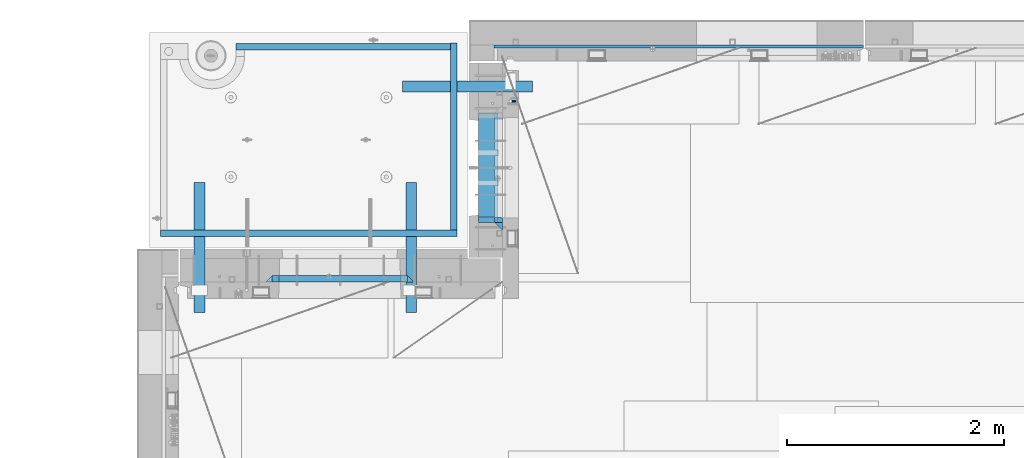
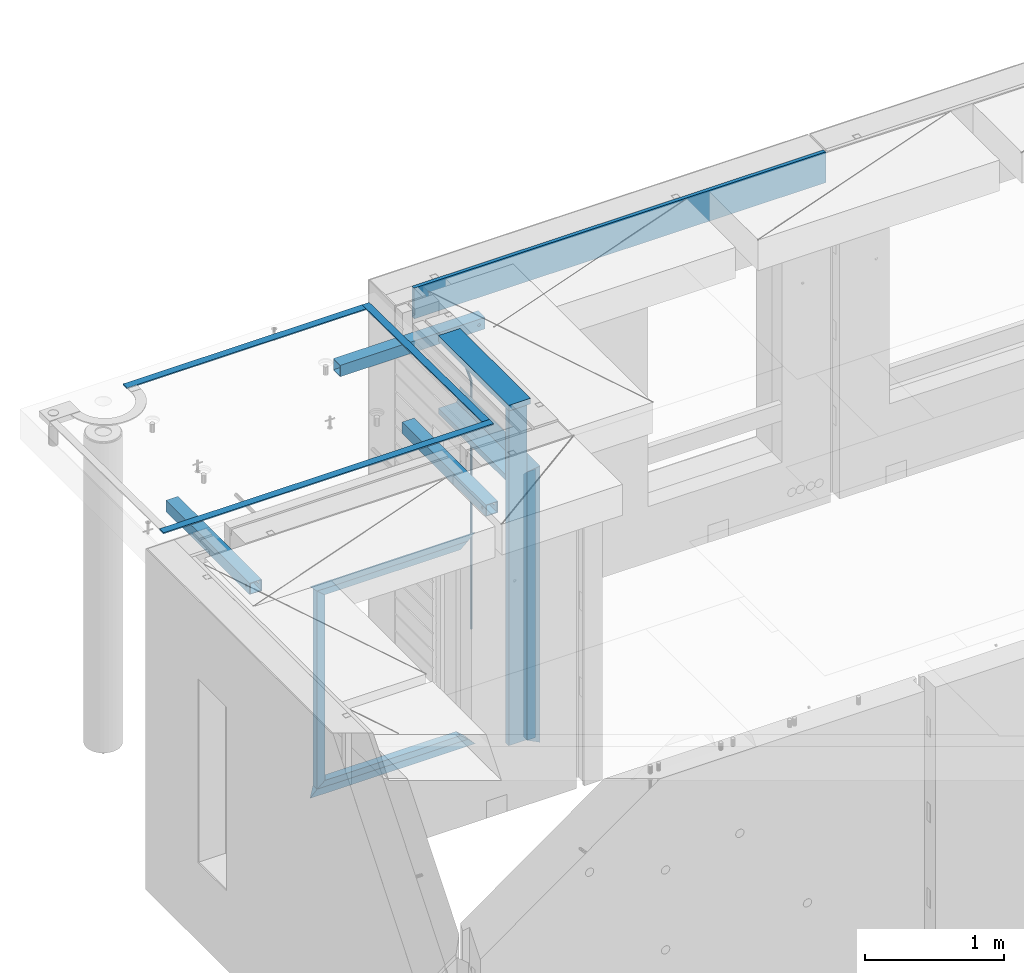
# One storey, part 115 of 352: 19 beams, 7 elements without a shape of their own.
"""IFC2X3 building model written with IfcOpenShell, lengths in millimetres."""

from ifc_helpers import new_model, si_unit, frame, origin_with_axes, place, context, subcontext, project, spatial, faceted_brep, material, type_object, element, aggregate, save


model = new_model("IFC2X3")

# Units and contexts
model_context = context("Model", 3, precision=1e-05, world=origin_with_axes())
body_context = subcontext(model_context, "Body", "Model", "MODEL_VIEW")
ifc_project = project(units=[si_unit("LENGTHUNIT", "METRE", prefix="MILLI"), si_unit("AREAUNIT", "SQUARE_METRE"), si_unit("VOLUMEUNIT", "CUBIC_METRE"), si_unit("MASSUNIT", "GRAM", prefix="KILO"), si_unit("TIMEUNIT", "SECOND"), si_unit("PLANEANGLEUNIT", "RADIAN"), si_unit("SOLIDANGLEUNIT", "STERADIAN"), si_unit("THERMODYNAMICTEMPERATUREUNIT", "DEGREE_CELSIUS"), si_unit("LUMINOUSINTENSITYUNIT", "LUMEN")], contexts=[model_context])

# Site, building, storey
site_placement = place(None, origin_with_axes())
site = spatial("IfcSite", under=ifc_project, at=site_placement, CompositionType="ELEMENT")
building_placement = place(site_placement, origin_with_axes())
building = spatial("IfcBuilding", under=site, at=building_placement, CompositionType="ELEMENT")
storey_placement = place(building_placement, origin_with_axes())
storey = spatial("IfcBuildingStorey", under=building, at=storey_placement, Name="6", CompositionType="ELEMENT", Elevation=0.0)

# Assembly, beams
assembly_1_placement = place(storey_placement, origin_with_axes())
assembly_1 = element("IfcElementAssembly", 1, at=assembly_1_placement, inside=storey, AssemblyPlace="NOTDEFINED", PredefinedType="REINFORCEMENT_UNIT")
ifc_material_1 = material(Name="CONCRETE/C25/30")
beam_type_1 = type_object("IfcBeamType", PredefinedType="NOTDEFINED")
beam_1_placement = place(assembly_1_placement, frame((10955.0, 22209.9998901814, 99140.0), z_axis=(0.0, 0.0, -1.0), x_axis=(0.0, -1.0, 0.0)))
beam_1 = element("IfcBeam", 2, at=beam_1_placement, type_object=beam_type_1, material=ifc_material_1, Name="SK", context=body_context, shape_type="Brep", body=[
    faceted_brep([(70.0000000000164, -35.0, 35.0), (70.0000000000164, 35.0, 35.0), (0.0, -35.0, -35.0), (1079.99961853027, -35.0, 35.0), (1079.99961853027, 35.0, 35.0), (1149.99961853027, -35.0, -35.0)], [[[0, 1, 2]], [[1, 0, 3, 4]], [[2, 1, 4, 5]], [[0, 2, 5, 3]], [[5, 4, 3]]]),
])
beam_2_placement = place(assembly_1_placement, frame((10955.0, 21095.0002716511, 99175.0), z_axis=(0.0, 1.0, 0.0), x_axis=(0.0, 0.0, -1.0)))
beam_2 = element("IfcBeam", 3, at=beam_2_placement, type_object=beam_type_1, material=ifc_material_1, Name="SK", context=body_context, shape_type="Brep", body=[
    faceted_brep([(2420.0, -35.0, 35.0), (2420.0, -35.0, -35.0), (2420.0, 35.0, 35.0), (70.0000000000164, -35.0, 35.0), (0.0, -35.0, -35.0), (70.0000000000164, 35.0, 35.0)], [[[0, 1, 2]], [[1, 0, 3, 4]], [[2, 1, 4, 5]], [[0, 2, 5, 3]], [[3, 5, 4]]]),
])
beam_type_2 = type_object("IfcBeamType", PredefinedType="NOTDEFINED")
beam_3_placement = place(assembly_1_placement, frame((10955.0, 21155.0002716511, 99105.0), z_axis=(0.0, 1.0, 0.0), x_axis=(0.0, 0.0, -1.0)))
beam_3 = element("IfcBeam", 4, at=beam_3_placement, type_object=beam_type_2, material=ifc_material_1, Name="SK", context=body_context, shape_type="Brep", body=[
    faceted_brep([(2350.0, -35.0, -25.0), (2350.0, 35.0, -25.0), (2350.0, 35.0, 20.6410256410309), (2350.0, -35.0, 18.8461538461561), (43.8461538461561, -35.0, 18.8461538461543), (0.0, -35.0, -25.0), (0.0, 35.0, -25.0), (45.6410256410309, 35.0, 20.6410256410254)], [[[0, 1, 2, 3]], [[0, 3, 4, 5]], [[1, 0, 5, 6]], [[2, 1, 6, 7]], [[3, 2, 7, 4]], [[7, 6, 5, 4]]]),
])
ifc_material_2 = material(Name="TIMBER")
beam_type_3 = type_object("IfcBeamType", Name="50X150", PredefinedType="NOTDEFINED")
beam_4_placement = place(assembly_1_placement, frame((10845.0, 22139.9998901814, 99080.0), z_axis=(0.0, 0.0, -1.0), x_axis=(0.0, -1.0, 0.0)))
beam_4 = element("IfcBeam", 5, at=beam_4_placement, type_object=beam_type_3, material=ifc_material_2, ObjectType="50X150", context=body_context, shape_type="Brep", body=[
    faceted_brep([(0.0, 75.0, -25.0), (1.81898940354586e-12, 75.0, 25.0), (1009.99961853027, 75.0, 25.0), (1009.99961853027, 75.0, -25.0), (1.81898940354586e-12, -75.0000000000009, 25.0), (1009.99961853027, -75.0, 25.0), (0.0, -75.0, -25.0), (1009.99961853027, -75.0, -25.0)], [[[0, 1, 2, 3]], [[1, 4, 5, 2]], [[4, 6, 7, 5]], [[6, 0, 3, 7]], [[5, 7, 3, 2]], [[6, 4, 1, 0]]]),
])
beam_5_placement = place(assembly_1_placement, frame((10845.0, 21155.0002716511, 99690.0), z_axis=(0.0, 1.0, 0.0), x_axis=(0.0, 0.0, -1.0)))
beam_5 = element("IfcBeam", 6, at=beam_5_placement, type_object=beam_type_3, material=ifc_material_2, ObjectType="50X150", context=body_context, shape_type="Brep", body=[
    faceted_brep([(0.0, 75.0, -25.0), (1.81898940354586e-12, 75.0, 25.0), (2930.0, 75.0, 25.0), (2930.0, 75.0, -25.0), (1.81898940354586e-12, -75.0000000000009, 25.0), (2930.0, -75.0, 25.0), (0.0, -75.0, -25.0), (2930.0, -75.0, -25.0)], [[[0, 1, 2, 3]], [[1, 4, 5, 2]], [[4, 6, 7, 5]], [[6, 0, 3, 7]], [[5, 7, 3, 2]], [[6, 4, 1, 0]]]),
])
ifc_material_3 = material()
beam_type_4 = type_object("IfcBeamType", Name="D20", PredefinedType="NOTDEFINED")
beam_6_placement = place(assembly_1_placement, frame((11065.0, 22249.9963332647, 99407.5), z_axis=(0.999999913638316, -0.000415599999849952, 0.0), x_axis=(0.0, 0.0, -1.0)))
beam_6 = element("IfcBeam", 7, at=beam_6_placement, type_object=beam_type_4, material=ifc_material_3, Name="JM20", ObjectType="D20", context=body_context, shape_type="Brep", body=[
    faceted_brep([(0.0, -10.0, 0.0), (-4.19531716033816e-08, -7.07106781186667, -7.07106781187031), (113.248091332178, -7.0710684840451, -7.0710678117357), (113.248091314759, -10.0000006713562, -2.51020537689328e-10), (0.0, 0.0, -10.0), (113.248091374131, -6.72178430249915e-07, -9.99999999986903), (4.196772351861e-08, 7.07106781186303, -7.07106781186667), (113.248091416113, 7.07106713968824, -7.07106781173934), (0.0, 10.0, 0.0), (113.248091433488, 9.99999932782521, 1.30967237055302e-10), (4.196772351861e-08, 7.07106781185939, 7.07106781185939), (113.248091416113, 7.0710671396846, 7.071067811994), (0.0, 0.0, 10.0), (113.248091374131, -6.72174792271107e-07, 10.0000000001273), (-4.19531716033816e-08, -7.07106781187031, 7.07106781185939), (113.248091332178, -7.0710684840451, 7.071067811994), (130.699843527167, -7.06993249763036, -4.33745683788584), (128.538066582521, -9.99900540317321, 2.39499413731755), (131.594536475241, 0.00119355250353692, -7.12624594330919), (130.698046432328, 7.07220300913468, -4.33773834422391), (128.535525107087, 10.0009944322555, 2.39459602660281), (126.373748162892, 7.07192152754578, 9.1270470011732), (125.479055214906, 0.000795477419160306, 11.9158361066184), (126.37554525779, -7.07021397921199, 9.12732850753673), (240.336258550378, -7.05529970173666, 30.8729495437874), (238.174481606227, -9.98437260450009, 37.6054005176375), (241.230951498423, 0.0158263482953771, 28.0841604381058), (240.334461455612, 7.0868358050102, 30.8726680369582), (238.171940130502, 10.0156272283348, 37.6050024077231), (236.010163186409, 7.08655432384694, 44.3374533824244), (235.115470238379, 0.0154282738185429, 47.1262424881097), (236.011960281176, -7.05558118289991, 44.3377348892536), (253.461915329972, -7.05444528127919, 32.9289287376414), (253.46191532613, -9.98337746617108, 39.9999965521893), (253.461915339081, 0.0166225284556276, 29.9999965443676), (253.461915348205, 7.08769034247234, 32.9289287273205), (253.461915352003, 10.0166225357716, 39.9999965370152), (253.461915348293, 7.08769035281148, 47.0710643509774), (253.461915339183, 0.0166225430875784, 49.999996544273), (253.46191533003, -7.05444527093641, 47.0710643613093), (2417.50000002384, -7.0544364694706, 32.9289287374122), (2417.5000000337, -9.98336865393321, 39.9999965507959), (2417.49999999997, 0.0166313408753922, 29.9999965456082), (2417.49999997609, 7.08769915426274, 32.9289287300708), (2417.4999999662, 10.0166313460668, 39.9999965404204), (2417.49999997608, 7.08769916160054, 47.0710643538114), (2417.49999999994, 0.0166313512581837, 49.9999965456154), (2417.50000002382, -7.05443646212916, 47.0710643611455)], [[[0, 1, 2, 3]], [[1, 4, 5, 2]], [[4, 6, 7, 5]], [[6, 8, 9, 7]], [[8, 10, 11, 9]], [[10, 12, 13, 11]], [[12, 14, 15, 13]], [[14, 0, 3, 15]], [[14, 12, 10, 8, 6, 4, 1, 0]], [[3, 2, 16, 17]], [[2, 5, 18, 16]], [[5, 7, 19, 18]], [[7, 9, 20, 19]], [[9, 11, 21, 20]], [[11, 13, 22, 21]], [[13, 15, 23, 22]], [[15, 3, 17, 23]], [[17, 16, 24, 25]], [[16, 18, 26, 24]], [[18, 19, 27, 26]], [[19, 20, 28, 27]], [[20, 21, 29, 28]], [[21, 22, 30, 29]], [[22, 23, 31, 30]], [[23, 17, 25, 31]], [[25, 24, 32, 33]], [[24, 26, 34, 32]], [[26, 27, 35, 34]], [[27, 28, 36, 35]], [[28, 29, 37, 36]], [[29, 30, 38, 37]], [[30, 31, 39, 38]], [[31, 25, 33, 39]], [[33, 32, 40, 41]], [[32, 34, 42, 40]], [[34, 35, 43, 42]], [[35, 36, 44, 43]], [[36, 37, 45, 44]], [[37, 38, 46, 45]], [[38, 39, 47, 46]], [[39, 33, 41, 47]], [[42, 43, 44, 45, 46, 47, 41, 40]]]),
])

# Assemblies, beams
assembly_2_placement = place(storey_placement, origin_with_axes())
assembly_2 = element("IfcElementAssembly", 8, at=assembly_2_placement, inside=storey, AssemblyPlace="NOTDEFINED", PredefinedType="REINFORCEMENT_UNIT")
assembly_3_placement = place(assembly_2_placement, origin_with_axes())
assembly_3 = element("IfcElementAssembly", 9, at=assembly_3_placement, AssemblyPlace="NOTDEFINED", PredefinedType="NOTDEFINED")
ifc_material_4 = material(Name="Undefined/350")
beam_type_5 = type_object("IfcBeamType", Name="100X100X5", PredefinedType="NOTDEFINED")
beam_7_placement = place(assembly_3_placement, frame((10069.9865573969, 22385.0401432011, 99555.0), z_axis=(0.0, 0.0, 1.0), x_axis=(0.999999999752625, -2.22429999942101e-05, 0.0)))
beam_7 = element("IfcBeam", 10, at=beam_7_placement, type_object=beam_type_5, material=ifc_material_4, ObjectType="100X100X5", context=body_context, shape_type="Brep", body=[
    faceted_brep([(1156.2510802317, 44.9999999999982, 10.8253175473074), (1156.25107855315, 50.0256005946221, 10.8253175473074), (1160.82639610046, 50.0256021227788, 6.25), (1160.82639777901, 44.9999999999982, 6.25), (1150.00108023171, 44.9999999999982, 12.5), (1150.00107855316, 50.0255985071226, 12.5), (1143.75108023171, 44.9999999999982, 10.8253175473074), (1143.75107855316, 50.0255964196231, 10.8253175473074), (1139.1757626844, 44.9999999999982, 6.25), (1139.17576100585, 50.0255948914664, 6.25), (1137.5010802317, 44.9999999999982, 0.0), (1137.50107855316, 50.0255943321226, 0.0), (1139.1757626844, 44.9999999999982, -6.25), (1139.17576100585, 50.0255948914664, -6.25), (1143.75108023171, 44.9999999999982, -10.8253175473074), (1143.75107855316, 50.0255964196231, -10.8253175473074), (1150.00108023171, 44.9999999999982, -12.5), (1150.00107855316, 50.0255985071226, -12.5), (1156.2510802317, 44.9999999999982, -10.8253175473074), (1156.25107855315, 50.0256005946221, -10.8253175473074), (1160.82639777901, 44.9999999999982, -6.25), (1160.82639610046, 50.0256021227788, -6.25), (1162.50108023171, 44.9999999999982, 0.0), (1162.50107855316, 50.0256026821226, 0.0), (1156.25111195316, -49.9743994042774, 10.8253175473074), (1156.25111029171, -44.9999999999991, 10.8253175473074), (1160.82642783901, -44.9999999999991, 6.25), (1160.82642950046, -49.9743978761207, 6.25), (1150.00111195316, -49.9744014917787, 12.5), (1150.00111029171, -44.9999999999991, 12.5), (1143.75111195316, -49.9744035792783, 10.8253175473074), (1143.75111029171, -44.9999999999991, 10.8253175473074), (1139.17579440585, -49.9744051074349, 6.25), (1139.1757927444, -44.9999999999991, 6.25), (1137.50111195316, -49.9744056667778, 0.0), (1137.50111029171, -44.9999999999991, 0.0), (1139.17579440585, -49.9744051074349, -6.25), (1139.1757927444, -44.9999999999991, -6.25), (1143.75111195316, -49.9744035792783, -10.8253175473074), (1143.75111029171, -44.9999999999991, -10.8253175473074), (1150.00111195316, -49.9744014917787, -12.5), (1150.00111029171, -44.9999999999991, -12.5), (1156.25111195316, -49.9743994042774, -10.8253175473074), (1156.25111029171, -44.9999999999991, -10.8253175473074), (1160.82642950046, -49.9743978761207, -6.25), (1160.82642783901, -44.9999999999991, -6.25), (1162.50111195316, -49.9743973167779, 0.0), (1162.50111029171, -44.9999999999991, 0.0), (1.81898940354586e-12, -50.0000000000009, -50.0), (1.81898940354586e-12, 49.9999999999991, -50.0), (1200.00449189278, 49.9999999999982, -50.0), (1200.00449189278, -50.0000000000009, -50.0), (1.81898940354586e-12, 49.9999999999991, 50.0), (1.81898940354586e-12, -50.0000000000009, 50.0), (1200.00449189278, -50.0000000000009, 50.0), (1200.00449189278, 49.9999999999982, 50.0), (0.0, 44.9999999999991, 45.0), (1.81898940354586e-12, -45.0000000000009, 45.0), (1.81898940354586e-12, -45.0000000000009, -45.0), (0.0, 44.9999999999991, -45.0), (1200.00449189278, 44.9999999999982, -45.0), (1200.00449189278, 44.9999999999982, 45.0), (1200.00449189278, -45.0000000000009, 45.0), (1200.00449189278, -45.0000000000009, -45.0)], [[[0, 1, 2, 3]], [[4, 5, 1, 0]], [[6, 7, 5, 4]], [[8, 9, 7, 6]], [[10, 11, 9, 8]], [[12, 13, 11, 10]], [[14, 15, 13, 12]], [[16, 17, 15, 14]], [[18, 19, 17, 16]], [[20, 21, 19, 18]], [[22, 23, 21, 20]], [[3, 2, 23, 22]], [[24, 25, 26, 27]], [[28, 29, 25, 24]], [[30, 31, 29, 28]], [[32, 33, 31, 30]], [[34, 35, 33, 32]], [[36, 37, 35, 34]], [[38, 39, 37, 36]], [[40, 41, 39, 38]], [[42, 43, 41, 40]], [[44, 45, 43, 42]], [[46, 47, 45, 44]], [[27, 26, 47, 46]], [[48, 49, 50, 51]], [[52, 53, 54, 55]], [[49, 52, 55, 50], [1, 5, 7, 9, 11, 13, 15, 17, 19, 21, 23, 2]], [[48, 53, 52, 49], [56, 57, 58, 59]], [[56, 59, 60, 61], [18, 16, 14, 12, 10, 8, 6, 4, 0, 3, 22, 20]], [[57, 56, 61, 62]], [[58, 57, 62, 63], [25, 29, 31, 33, 35, 37, 39, 41, 43, 45, 47, 26]], [[59, 58, 63, 60]], [[54, 51, 50, 55], [62, 61, 60, 63]], [[53, 48, 51, 54], [42, 40, 38, 36, 34, 32, 30, 28, 24, 27, 46, 44]]]),
])
aggregate(assembly_3, [beam_7])
assembly_4_placement = place(assembly_2_placement, origin_with_axes())
assembly_4 = element("IfcElementAssembly", 11, at=assembly_4_placement, AssemblyPlace="NOTDEFINED", PredefinedType="NOTDEFINED")
beam_8_placement = place(assembly_4_placement, frame((10150.0001432011, 21500.0034426031, 99555.0), z_axis=(0.0, 0.0, 1.0), x_axis=(-2.2242999997242e-05, -0.999999999752625, 0.0)))
beam_8 = element("IfcBeam", 12, at=beam_8_placement, type_object=beam_type_5, material=ifc_material_4, ObjectType="100X100X5", context=body_context, shape_type="Brep", body=[
    faceted_brep([(1143.75108023171, 44.9999999999982, -10.8253175473074), (1143.75107855316, 50.0255964196231, -10.8253175473074), (1139.17576100585, 50.0255948914664, -6.25), (1139.1757626844, 44.9999999999982, -6.25), (1150.00108023171, 44.9999999999982, -12.5), (1150.00107855316, 50.0255985071226, -12.5), (1156.2510802317, 44.9999999999982, -10.8253175473074), (1156.25107855315, 50.0256005946221, -10.8253175473074), (1160.82639777901, 44.9999999999982, -6.25), (1160.82639610046, 50.0256021227788, -6.25), (1162.50108023171, 44.9999999999982, 0.0), (1162.50107855316, 50.0256026821226, 0.0), (1160.82639777901, 44.9999999999982, 6.25), (1160.82639610046, 50.0256021227788, 6.25), (1156.2510802317, 44.9999999999982, 10.8253175473074), (1156.25107855315, 50.0256005946221, 10.8253175473074), (1150.00108023171, 44.9999999999982, 12.5), (1150.00107855316, 50.0255985071226, 12.5), (1143.75108023171, 44.9999999999982, 10.8253175473074), (1143.75107855316, 50.0255964196231, 10.8253175473074), (1139.1757626844, 44.9999999999982, 6.25), (1139.17576100585, 50.0255948914664, 6.25), (1137.5010802317, 44.9999999999982, 0.0), (1137.50107855316, 50.0255943321226, 0.0), (1143.75111195316, -49.9744035792783, -10.8253175473074), (1143.75111029171, -44.9999999999991, -10.8253175473074), (1139.1757927444, -44.9999999999991, -6.25), (1139.17579440585, -49.9744051074349, -6.25), (1150.00111195316, -49.9744014917787, -12.5), (1150.00111029171, -44.9999999999991, -12.5), (1156.25111195316, -49.9743994042774, -10.8253175473074), (1156.25111029171, -44.9999999999991, -10.8253175473074), (1160.82642950046, -49.9743978761207, -6.25), (1160.82642783901, -44.9999999999991, -6.25), (1162.50111195316, -49.9743973167779, 0.0), (1162.50111029171, -44.9999999999991, 0.0), (1160.82642950046, -49.9743978761207, 6.25), (1160.82642783901, -44.9999999999991, 6.25), (1156.25111195316, -49.9743994042774, 10.8253175473074), (1156.25111029171, -44.9999999999991, 10.8253175473074), (1150.00111195316, -49.9744014917787, 12.5), (1150.00111029171, -44.9999999999991, 12.5), (1143.75111195316, -49.9744035792783, 10.8253175473074), (1143.75111029171, -44.9999999999991, 10.8253175473074), (1139.17579440585, -49.9744051074349, 6.25), (1139.1757927444, -44.9999999999991, 6.25), (1137.50111195316, -49.9744056667778, 0.0), (1137.50111029171, -44.9999999999991, 0.0), (1.81898940354586e-12, -50.0000000000009, -50.0), (1.81898940354586e-12, 49.9999999999991, -50.0), (1200.00449189278, 49.9999999999982, -50.0), (1200.00449189278, -50.0000000000009, -50.0), (1.81898940354586e-12, 49.9999999999991, 50.0), (1.81898940354586e-12, -50.0000000000009, 50.0), (1200.00449189278, -50.0000000000009, 50.0), (1200.00449189278, 49.9999999999982, 50.0), (0.0, 44.9999999999991, 45.0), (1.81898940354586e-12, -45.0000000000009, 45.0), (1.81898940354586e-12, -45.0000000000009, -45.0), (0.0, 44.9999999999991, -45.0), (1200.00449189278, 44.9999999999982, -45.0), (1200.00449189278, 44.9999999999982, 45.0), (1200.00449189278, -45.0000000000009, 45.0), (1200.00449189278, -45.0000000000009, -45.0)], [[[0, 1, 2, 3]], [[4, 5, 1, 0]], [[6, 7, 5, 4]], [[8, 9, 7, 6]], [[10, 11, 9, 8]], [[12, 13, 11, 10]], [[14, 15, 13, 12]], [[16, 17, 15, 14]], [[18, 19, 17, 16]], [[20, 21, 19, 18]], [[22, 23, 21, 20]], [[3, 2, 23, 22]], [[24, 25, 26, 27]], [[28, 29, 25, 24]], [[30, 31, 29, 28]], [[32, 33, 31, 30]], [[34, 35, 33, 32]], [[36, 37, 35, 34]], [[38, 39, 37, 36]], [[40, 41, 39, 38]], [[42, 43, 41, 40]], [[44, 45, 43, 42]], [[46, 47, 45, 44]], [[27, 26, 47, 46]], [[48, 49, 50, 51]], [[52, 53, 54, 55]], [[49, 52, 55, 50], [15, 17, 19, 21, 23, 2, 1, 5, 7, 9, 11, 13]], [[48, 53, 52, 49], [56, 57, 58, 59]], [[56, 59, 60, 61], [6, 4, 0, 3, 22, 20, 18, 16, 14, 12, 10, 8]], [[57, 56, 61, 62]], [[58, 57, 62, 63], [39, 41, 43, 45, 47, 26, 25, 29, 31, 33, 35, 37]], [[59, 58, 63, 60]], [[54, 51, 50, 55], [62, 61, 60, 63]], [[53, 48, 51, 54], [30, 28, 24, 27, 46, 44, 42, 40, 38, 36, 34, 32]]]),
])
aggregate(assembly_4, [beam_8])
assembly_5_placement = place(assembly_2_placement, origin_with_axes())
assembly_5 = element("IfcElementAssembly", 13, at=assembly_5_placement, AssemblyPlace="NOTDEFINED", PredefinedType="NOTDEFINED")
beam_9_placement = place(assembly_5_placement, frame((8195.00014320107, 21500.0034426031, 99555.0), z_axis=(0.0, 0.0, 1.0), x_axis=(-2.2242999997242e-05, -0.999999999752625, 0.0)))
beam_9 = element("IfcBeam", 14, at=beam_9_placement, type_object=beam_type_5, material=ifc_material_4, ObjectType="100X100X5", context=body_context, shape_type="Brep", body=[
    faceted_brep([(1143.75108023171, 44.9999999999982, -10.8253175473074), (1143.75107855316, 50.0255964196231, -10.8253175473074), (1139.17576100585, 50.0255948914664, -6.25), (1139.1757626844, 44.9999999999982, -6.25), (1150.00108023171, 44.9999999999982, -12.5), (1150.00107855316, 50.0255985071226, -12.5), (1156.2510802317, 44.9999999999982, -10.8253175473074), (1156.25107855315, 50.0256005946221, -10.8253175473074), (1160.82639777901, 44.9999999999982, -6.25), (1160.82639610046, 50.0256021227788, -6.25), (1162.50108023171, 44.9999999999982, 0.0), (1162.50107855316, 50.0256026821226, 0.0), (1160.82639777901, 44.9999999999982, 6.25), (1160.82639610046, 50.0256021227788, 6.25), (1156.2510802317, 44.9999999999982, 10.8253175473074), (1156.25107855315, 50.0256005946221, 10.8253175473074), (1150.00108023171, 44.9999999999982, 12.5), (1150.00107855316, 50.0255985071226, 12.5), (1143.75108023171, 44.9999999999982, 10.8253175473074), (1143.75107855316, 50.0255964196231, 10.8253175473074), (1139.1757626844, 44.9999999999982, 6.25), (1139.17576100585, 50.0255948914664, 6.25), (1137.5010802317, 44.9999999999982, 0.0), (1137.50107855316, 50.0255943321226, 0.0), (1143.75111195316, -49.9744035792783, -10.8253175473074), (1143.75111029171, -44.9999999999991, -10.8253175473074), (1139.1757927444, -44.9999999999991, -6.25), (1139.17579440585, -49.9744051074349, -6.25), (1150.00111195316, -49.9744014917787, -12.5), (1150.00111029171, -44.9999999999991, -12.5), (1156.25111195316, -49.9743994042774, -10.8253175473074), (1156.25111029171, -44.9999999999991, -10.8253175473074), (1160.82642950046, -49.9743978761207, -6.25), (1160.82642783901, -44.9999999999991, -6.25), (1162.50111195316, -49.9743973167779, 0.0), (1162.50111029171, -44.9999999999991, 0.0), (1160.82642950046, -49.9743978761207, 6.25), (1160.82642783901, -44.9999999999991, 6.25), (1156.25111195316, -49.9743994042774, 10.8253175473074), (1156.25111029171, -44.9999999999991, 10.8253175473074), (1150.00111195316, -49.9744014917787, 12.5), (1150.00111029171, -44.9999999999991, 12.5), (1143.75111195316, -49.9744035792783, 10.8253175473074), (1143.75111029171, -44.9999999999991, 10.8253175473074), (1139.17579440585, -49.9744051074349, 6.25), (1139.1757927444, -44.9999999999991, 6.25), (1137.50111195316, -49.9744056667778, 0.0), (1137.50111029171, -44.9999999999991, 0.0), (1.81898940354586e-12, -50.0000000000009, -50.0), (1.81898940354586e-12, 49.9999999999991, -50.0), (1200.00449189278, 49.9999999999982, -50.0), (1200.00449189278, -50.0000000000009, -50.0), (1.81898940354586e-12, 49.9999999999991, 50.0), (1.81898940354586e-12, -50.0000000000009, 50.0), (1200.00449189278, -50.0000000000009, 50.0), (1200.00449189278, 49.9999999999982, 50.0), (0.0, 44.9999999999991, 45.0), (1.81898940354586e-12, -45.0000000000009, 45.0), (1.81898940354586e-12, -45.0000000000009, -45.0), (0.0, 44.9999999999991, -45.0), (1200.00449189278, 44.9999999999982, -45.0), (1200.00449189278, 44.9999999999982, 45.0), (1200.00449189278, -45.0000000000009, 45.0), (1200.00449189278, -45.0000000000009, -45.0)], [[[0, 1, 2, 3]], [[4, 5, 1, 0]], [[6, 7, 5, 4]], [[8, 9, 7, 6]], [[10, 11, 9, 8]], [[12, 13, 11, 10]], [[14, 15, 13, 12]], [[16, 17, 15, 14]], [[18, 19, 17, 16]], [[20, 21, 19, 18]], [[22, 23, 21, 20]], [[3, 2, 23, 22]], [[24, 25, 26, 27]], [[28, 29, 25, 24]], [[30, 31, 29, 28]], [[32, 33, 31, 30]], [[34, 35, 33, 32]], [[36, 37, 35, 34]], [[38, 39, 37, 36]], [[40, 41, 39, 38]], [[42, 43, 41, 40]], [[44, 45, 43, 42]], [[46, 47, 45, 44]], [[27, 26, 47, 46]], [[48, 49, 50, 51]], [[52, 53, 54, 55]], [[49, 52, 55, 50], [15, 17, 19, 21, 23, 2, 1, 5, 7, 9, 11, 13]], [[48, 53, 52, 49], [56, 57, 58, 59]], [[56, 59, 60, 61], [6, 4, 0, 3, 22, 20, 18, 16, 14, 12, 10, 8]], [[57, 56, 61, 62]], [[58, 57, 62, 63], [39, 41, 43, 45, 47, 26, 25, 29, 31, 33, 35, 37]], [[59, 58, 63, 60]], [[54, 51, 50, 55], [62, 61, 60, 63]], [[53, 48, 51, 54], [30, 28, 24, 27, 46, 44, 42, 40, 38, 36, 34, 32]]]),
])
aggregate(assembly_5, [beam_9])
ifc_material_5 = material(Name="CONCRETE/Concrete_Undefined")
beam_type_6 = type_object("IfcBeamType", PredefinedType="NOTDEFINED")
beam_10_placement = place(assembly_2_placement, frame((8529.99466999203, 22755.2837502302, 99704.830444231), z_axis=(-8.94119999996021e-05, 2.00000067707701e-09, 0.999999996002747), x_axis=(0.999999995749149, -2.25209999937896e-05, 8.94119999812374e-05)))
beam_10 = element("IfcBeam", 15, at=beam_10_placement, type_object=beam_type_6, material=ifc_material_5, context=body_context, shape_type="Brep", body=[
    faceted_brep([(2.5465851649642e-11, 29.9999999999982, -4.99999999998545), (-2.91038304567337e-11, 29.9999999999982, 5.0), (1980.00575712919, 30.0, 5.0), (1980.00575712919, 30.0, -5.0), (-2.5465851649642e-11, -30.0000000000018, 5.0), (1980.00575712919, -30.0, 5.0), (2.72848410531878e-11, -30.0000000000018, -4.99999999998545), (1980.00575712919, -30.0, -5.00000000001455)], [[[0, 1, 2, 3]], [[1, 4, 5, 2]], [[4, 6, 7, 5]], [[6, 0, 3, 7]], [[5, 7, 3, 2]], [[6, 4, 1, 0]]]),
])
beam_11_placement = place(assembly_2_placement, frame((10540.0586106742, 21059.9845873458, 99725.6637899649), z_axis=(-4.06999999693443e-07, 0.0121707750045615, 0.999925933374879), x_axis=(-3.34759999933477e-05, 0.999925932814682, -0.0121707749977451)))
beam_11 = element("IfcBeam", 16, at=beam_11_placement, type_object=beam_type_6, material=ifc_material_5, context=body_context, shape_type="Brep", body=[
    faceted_brep([(2.5465851649642e-11, 29.9999999999982, -4.99999999998545), (-2.91038304567337e-11, 29.9999999999982, 5.0), (1725.44357525616, 30.0000000000036, 5.00000000001455), (1725.4435752563, 30.0, -4.9999999999709), (-2.5465851649642e-11, -30.0000000000018, 5.0), (1725.44357525616, -29.9999999999964, 5.0000000000291), (2.72848410531878e-11, -30.0000000000018, -4.99999999998545), (1725.4435752563, -30.0, -4.99999999998545)], [[[0, 1, 2, 3]], [[1, 4, 5, 2]], [[4, 6, 7, 5]], [[6, 0, 3, 7]], [[5, 7, 3, 2]], [[6, 4, 1, 0]]]),
])
beam_12_placement = place(assembly_2_placement, frame((7834.99819277187, 21029.998155674, 99725.2788443216), z_axis=(-0.000140627000015522, 4.00000135459113e-09, 0.999999990112023), x_axis=(0.999999989763253, -2.64109999939869e-05, 0.000140626999967189)))
beam_12 = element("IfcBeam", 17, at=beam_12_placement, type_object=beam_type_6, material=ifc_material_5, context=body_context, shape_type="Brep", body=[
    faceted_brep([(2.5465851649642e-11, 29.9999999999982, -4.99999999998545), (-2.91038304567337e-11, 29.9999999999982, 5.0), (2735.00002544224, 30.0, 5.0), (2735.00002544224, 30.0, -5.0), (-2.5465851649642e-11, -30.0000000000018, 5.0), (2735.00002544224, -29.9999999999964, 5.0), (2.72848410531878e-11, -30.0000000000018, -4.99999999998545), (2735.00002544224, -29.9999999999964, -5.0)], [[[0, 1, 2, 3]], [[1, 4, 5, 2]], [[4, 6, 7, 5]], [[6, 0, 3, 7]], [[5, 7, 3, 2]], [[6, 4, 1, 0]]]),
])
aggregate(assembly_2, [assembly_3, assembly_4, assembly_5, beam_10, beam_11, beam_12])

# Assembly, beams
assembly_6_placement = place(storey_placement, origin_with_axes())
assembly_6 = element("IfcElementAssembly", 18, at=assembly_6_placement, inside=storey, AssemblyPlace="NOTDEFINED", PredefinedType="REINFORCEMENT_UNIT")
beam_type_7 = type_object("IfcBeamType", PredefinedType="NOTDEFINED")
beam_13_placement = place(assembly_6_placement, frame((10174.9997107317, 20609.9951872276, 99145.0), z_axis=(0.0, 0.0, -1.0), x_axis=(-1.0, 3.00000001838171e-08, 0.0)))
beam_13 = element("IfcBeam", 19, at=beam_13_placement, type_object=beam_type_7, material=ifc_material_1, Name="SK", context=body_context, shape_type="Brep", body=[
    faceted_brep([(60.0000000000073, 30.0, 30.0), (0.0, -30.0, -30.0), (60.0000000000073, -30.0, 30.0), (1309.99847412109, 30.0, 30.0), (1369.99847412109, -30.0, -30.0), (1309.99847412109, -30.0, 30.0)], [[[0, 1, 2]], [[1, 0, 3, 4]], [[2, 1, 4, 5]], [[0, 2, 5, 3]], [[3, 5, 4]]]),
])
beam_14_placement = place(assembly_6_placement, frame((10114.9997107317, 20609.9951872276, 99085.0), z_axis=(0.0, 0.0, -1.0), x_axis=(-1.0, 3.00000001838171e-08, 0.0)))
beam_14 = element("IfcBeam", 20, at=beam_14_placement, type_object=beam_type_7, material=ifc_material_1, Name="SK", context=body_context, shape_type="Brep", body=[
    faceted_brep([(65.6741497967687, 29.999999998452, 26.2921283848846), (0.0, 30.0, -30.0), (0.0, -30.0, -30.0), (64.0525281752307, -29.999999998452, 24.9021669953072), (64.0525281752307, -29.999999998452, 24.0540540541406), (65.6741497967687, 29.999999998452, 25.6756756756804), (1185.94442006696, -29.999999998452, 24.0540540541406), (1184.32279844542, 29.999999998452, 25.6756756756804), (1184.32279844542, 29.999999998452, 26.2934362810629), (1249.99847412109, 29.999999998452, -30.0), (1249.99847412109, -29.999999998452, -30.0), (1185.94442006696, -29.999999998452, 24.9034748915001)], [[[0, 1, 2, 3]], [[4, 5, 0, 3]], [[6, 7, 5, 4]], [[1, 0, 5, 7, 8, 9]], [[2, 1, 9, 10]], [[6, 4, 3, 2, 10, 11]], [[7, 6, 11, 8]], [[9, 8, 11, 10]]]),
])
beam_15_placement = place(assembly_6_placement, frame((8805.00123661063, 20609.9951872276, 97350.0), z_axis=(0.0, 0.0, 1.0), x_axis=(1.0, 0.0, 0.0)))
beam_15 = element("IfcBeam", 21, at=beam_15_placement, type_object=beam_type_7, material=ifc_material_1, Name="SK", context=body_context, shape_type="Brep", body=[
    faceted_brep([(1309.99847412109, 30.0, 30.0), (1309.99847412109, -30.0, 30.0), (1369.99847412109, -30.0, -30.0), (60.0000000000073, 30.0, 30.0), (60.0000000000073, -30.0, 30.0), (0.0, -30.0, -30.0)], [[[0, 1, 2]], [[3, 4, 1, 0]], [[4, 5, 2, 1]], [[5, 3, 0, 2]], [[3, 5, 4]]]),
])
beam_16_placement = place(assembly_6_placement, frame((8865.00123661063, 20609.9951872276, 97410.0), z_axis=(0.0, 0.0, 1.0), x_axis=(1.0, 0.0, 0.0)))
beam_16 = element("IfcBeam", 22, at=beam_16_placement, type_object=beam_type_7, material=ifc_material_1, Name="SK", context=body_context, shape_type="Brep", body=[
    faceted_brep([(1184.32432432433, 29.999999998452, 26.2921283848846), (1185.94594594586, -29.999999998452, 24.9021669952926), (1249.99847412109, -29.999999998452, -30.0), (1249.99847412109, 29.999999998452, -30.0), (1184.32432432432, 29.9999988381387, 25.6756756756804), (1185.94594588314, -29.9999988381387, 24.0540541168593), (65.6756756756768, 30.0, 25.6756756756804), (64.0540540540533, -30.0, 24.0540540540533), (65.6756756756768, 30.0, 26.293436281092), (64.0540540540533, -30.0, 24.9034748914419), (0.0, -30.0, -30.0), (0.0, 30.0, -30.0)], [[[0, 1, 2, 3]], [[4, 5, 1, 0]], [[5, 4, 6, 7]], [[7, 6, 8, 9]], [[2, 1, 5, 7, 9, 10]], [[10, 11, 3, 2]], [[6, 4, 0, 3, 11, 8]], [[10, 9, 8, 11]]]),
])
beam_type_8 = type_object("IfcBeamType", PredefinedType="NOTDEFINED")
beam_17_placement = place(assembly_6_placement, frame((8900.00123661063, 20609.9951872276, 99115.0), z_axis=(1.0, 0.0, 0.0), x_axis=(0.0, 0.0, -1.0)))
beam_17 = element("IfcBeam", 23, at=beam_17_placement, type_object=beam_type_8, material=ifc_material_1, Name="SK", context=body_context, shape_type="Brep", body=[
    faceted_brep([(0.0, -30.0, -35.0), (54.9034748914273, -30.0, 29.0540540540533), (56.2934362811066, 30.0, 30.6756756756768), (0.0, 30.0, -35.0), (1678.70656371891, 30.0, 30.6756756756768), (1735.0, 30.0, -35.0), (1735.0, -30.0, -35.0), (1680.09652510857, -30.0, 29.0540540540533)], [[[0, 1, 2, 3]], [[3, 2, 4, 5]], [[5, 6, 0, 3]], [[1, 0, 6, 7]], [[2, 1, 7, 4]], [[6, 5, 4, 7]]]),
])
aggregate(assembly_6, [beam_13, beam_14, beam_17, beam_15, beam_16])

# Assembly, beam
assembly_7_placement = place(storey_placement, origin_with_axes())
assembly_7 = element("IfcElementAssembly", 24, at=assembly_7_placement, inside=storey, AssemblyPlace="NOTDEFINED", PredefinedType="REINFORCEMENT_UNIT")
beam_type_9 = type_object("IfcBeamType", Name="270X30", PredefinedType="NOTDEFINED")
beam_18_placement = place(assembly_7_placement, frame((14325.0, 22755.0, 99605.0), z_axis=(0.0, 0.0, 1.0), x_axis=(-1.0, 3.00000001838171e-08, 0.0)))
beam_18 = element("IfcBeam", 25, at=beam_18_placement, type_object=beam_type_9, material=ifc_material_1, ObjectType="270X30", context=body_context, shape_type="Brep", body=[
    faceted_brep([(0.0, 15.0, -135.0), (0.0, 15.0, 135.0), (3410.00000000003, 15.0, 135.0), (3410.00000000003, 15.0, -135.0), (0.0, -15.0, 135.0), (3410.00000000003, -15.0, 135.0), (0.0, -15.0, -135.0), (3410.00000000003, -15.0, -135.0)], [[[0, 1, 2, 3]], [[1, 4, 5, 2]], [[4, 6, 7, 5]], [[6, 0, 3, 7]], [[5, 7, 3, 2]], [[6, 4, 1, 0]]]),
])
aggregate(assembly_7, [beam_18])

# Beam
beam_type_10 = type_object("IfcBeamType", PredefinedType="NOTDEFINED")
beam_19_placement = place(assembly_1_placement, frame((10860.0, 21129.9999618525, 99715.0), z_axis=(0.0, 0.0, 1.0), x_axis=(0.0, 1.0, 0.0)))
beam_19 = element("IfcBeam", 26, at=beam_19_placement, type_object=beam_type_10, material=ifc_material_2, context=body_context, shape_type="Brep", body=[
    faceted_brep([(0.0, 90.0, -25.0), (0.0, 90.0, 25.0), (1009.99983857082, 90.0, 25.0), (1009.99983857082, 90.0, -25.0), (0.0, -90.0, 25.0), (1009.99983857082, -90.0, 25.0), (0.0, -90.0, -25.0), (1009.99983857082, -90.0, -25.0)], [[[0, 1, 2, 3]], [[1, 4, 5, 2]], [[4, 6, 7, 5]], [[6, 0, 3, 7]], [[5, 7, 3, 2]], [[6, 4, 1, 0]]]),
])

aggregate(assembly_1, [beam_6, beam_1, beam_2, beam_3, beam_4, beam_5, beam_19])

save(model, "model.ifc")
